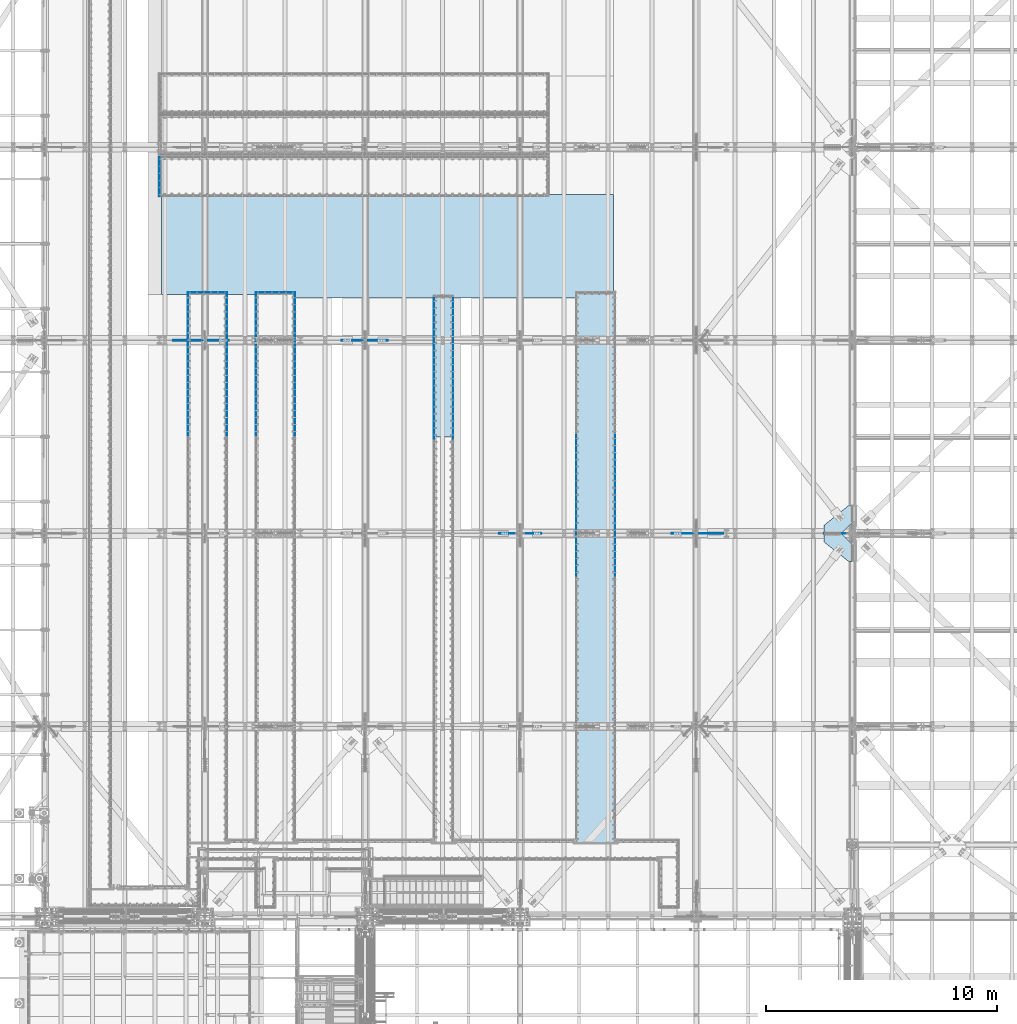
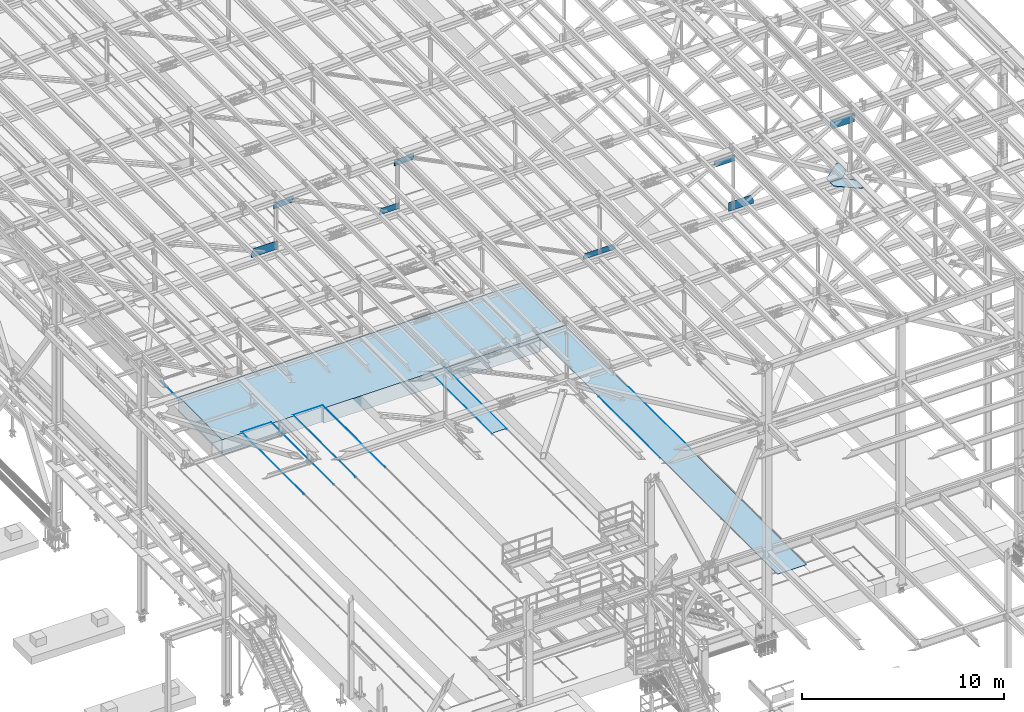
# One storey, part 2981 of 3843: 23 plates, 1 slab, 23 elements without a shape of their own.
"""IFC2X3 building model written with IfcOpenShell, lengths in millimetres."""

from ifc_helpers import new_model, si_unit, frame, origin_with_axes, place, context, subcontext, project, spatial, faceted_brep, material, type_object, element, aggregate, save


model = new_model("IFC2X3")

# Units and contexts
model_context = context("Model", 3, precision=1e-05, world=origin_with_axes())
body_context = subcontext(model_context, "Body", "Model", "MODEL_VIEW")
ifc_project = project(units=[si_unit("LENGTHUNIT", "METRE", prefix="MILLI"), si_unit("AREAUNIT", "SQUARE_METRE"), si_unit("VOLUMEUNIT", "CUBIC_METRE"), si_unit("MASSUNIT", "GRAM", prefix="KILO"), si_unit("TIMEUNIT", "SECOND"), si_unit("PLANEANGLEUNIT", "RADIAN"), si_unit("SOLIDANGLEUNIT", "STERADIAN"), si_unit("THERMODYNAMICTEMPERATUREUNIT", "DEGREE_CELSIUS"), si_unit("LUMINOUSINTENSITYUNIT", "LUMEN")], contexts=[model_context])

# Site, building, storey
site_placement = place(None, origin_with_axes())
site = spatial("IfcSite", under=ifc_project, at=site_placement, CompositionType="ELEMENT")
building_placement = place(site_placement, origin_with_axes())
building = spatial("IfcBuilding", under=site, at=building_placement, Name="Undefined", CompositionType="ELEMENT")
storey_placement = place(building_placement, origin_with_axes())
storey = spatial("IfcBuildingStorey", under=building, at=storey_placement, Name="Undefined", CompositionType="ELEMENT", Elevation=0.0)

# Assembly, plate
assembly_1_placement = place(storey_placement, origin_with_axes())
assembly_1 = element("IfcElementAssembly", 1, at=assembly_1_placement, inside=storey, Name="EMBED_ANGLE", AssemblyPlace="NOTDEFINED", PredefinedType="RIGID_FRAME")
ifc_material_1 = material(Name="STEEL/A36")
plate_type_1 = type_object("IfcPlateType", PredefinedType="NOTDEFINED")
plate_1_placement = place(assembly_1_placement, frame((47028.8619790039, 56784.8750000035, 30480.0000003815), z_axis=(0.0, 1.0, 0.0), x_axis=(0.0, 0.0, -1.0)))
plate_1 = element("IfcPlate", 2, at=plate_1_placement, type_object=plate_type_1, material=ifc_material_1, Name="PLATE", context=body_context, shape_type="Brep", body=[
    faceted_brep([(7.27595761418343e-12, 6.3499999046162, 0.0), (20.6374996185295, 6.35000000000218, -7.27595761418343e-12), (25.399999618523, 1.58750000001601, 4.76249999998981), (25.3999996185303, -6.34999999999854, 12.7000000000044), (0.0, -6.34999999999854, 12.6999998092651), (25.3999996154307, 1.58750000001601, 1697.41850000675), (25.3999996185303, -6.34999999999854, 1689.48100001796), (3.78626282326877e-07, -6.34999999999854, 1689.48100001796), (3.81471181754023e-07, 6.34999999999854, 1702.181), (20.6374996154154, 6.34999999999854, 1702.18100000139)], [[[0, 1, 2, 3, 4]], [[3, 2, 5, 6]], [[4, 3, 6, 7]], [[0, 4, 7, 8]], [[1, 0, 8, 9]], [[2, 1, 9, 5]], [[8, 7, 6, 5, 9]]]),
])
aggregate(assembly_1, [plate_1])

assembly_2_placement = place(storey_placement, origin_with_axes())
assembly_2 = element("IfcElementAssembly", 3, at=assembly_2_placement, inside=storey, Name="EMBED_ANGLE", AssemblyPlace="NOTDEFINED", PredefinedType="RIGID_FRAME")
plate_2_placement = place(assembly_2_placement, frame((51194.4935696441, 52635.1494804688, 30480.0000003815), z_axis=(1.0, 0.0, 0.0), x_axis=(0.0, 0.0, -1.0)))
plate_2 = element("IfcPlate", 4, at=plate_2_placement, type_object=plate_type_1, material=ifc_material_1, Name="PLATE", context=body_context, shape_type="Brep", body=[
    faceted_brep([(3.81471181754023e-07, 6.34999999555293, 1701.76888183631), (3.78611730411649e-07, -6.35000000441505, 1689.00497348848), (25.3999996185303, -6.35000000441505, 1689.00497348848), (25.4000000789456, 1.58749889564206, 1696.9424708618), (20.6375003659959, 6.34999999555293, 1701.76888183631), (25.3999996185303, -6.35000000002765, 12.6775651971911), (25.3999996198218, 1.58727214465034, 4.75431440180546), (20.6374996185295, 6.35000000000218, -7.27595761418343e-12), (7.27595761418343e-12, 6.3499999046162, 0.0), (2.84126144833863e-09, -6.35000000002765, 12.6775651971911)], [[[0, 1, 2, 3, 4]], [[3, 2, 5, 6]], [[4, 3, 6, 7]], [[0, 4, 7, 8]], [[1, 0, 8, 9]], [[2, 1, 9, 5]], [[8, 7, 6, 5, 9]]]),
])
aggregate(assembly_2, [plate_2])

assembly_3_placement = place(storey_placement, origin_with_axes())
assembly_3 = element("IfcElementAssembly", 5, at=assembly_3_placement, inside=storey, Name="EMBED_ANGLE", AssemblyPlace="NOTDEFINED", PredefinedType="RIGID_FRAME")
plate_3_placement = place(assembly_3_placement, frame((48254.4432063764, 52635.1500664063, 30480.0000003815), z_axis=(1.0, 0.0, 0.0), x_axis=(0.0, 0.0, -1.0)))
plate_3 = element("IfcPlate", 6, at=plate_3_placement, type_object=plate_type_1, material=ifc_material_1, Name="PLATE", context=body_context, shape_type="Brep", body=[
    faceted_brep([(3.81471181754023e-07, 6.34999999555293, 1701.76888183631), (3.7862264434807e-07, -6.35000000441505, 1689.0688799162), (25.3999996185303, -6.35000000441505, 1689.0688799162), (25.4000000789638, 1.58749890421313, 1697.00637963295), (20.6375003659959, 6.34999999555293, 1701.76888183631), (25.3999996185303, -6.35000000002037, 12.7000657744793), (25.3999996198218, 1.58727214579267, 4.76283263532969), (20.6374996185295, 6.35000000000218, -7.27595761418343e-12), (7.27595761418343e-12, 6.3499999046162, 0.0), (2.84853740595281e-09, -6.35000000002037, 12.7000657744793)], [[[0, 1, 2, 3, 4]], [[3, 2, 5, 6]], [[4, 3, 6, 7]], [[0, 4, 7, 8]], [[1, 0, 8, 9]], [[2, 1, 9, 5]], [[8, 7, 6, 5, 9]]]),
])
aggregate(assembly_3, [plate_3])

assembly_4_placement = place(storey_placement, origin_with_axes())
assembly_4 = element("IfcElementAssembly", 7, at=assembly_4_placement, inside=storey, Name="EMBED_ANGLE", AssemblyPlace="NOTDEFINED", PredefinedType="RIGID_FRAME")
plate_4_placement = place(assembly_4_placement, frame((66751.962, 46456.6001953125, 30480.0), z_axis=(0.0, -1.0, 0.0), x_axis=(0.0, 0.0, -1.0)))
plate_4 = element("IfcPlate", 8, at=plate_4_placement, type_object=plate_type_1, material=ifc_material_1, Name="PLATE", context=body_context, shape_type="Brep", body=[
    faceted_brep([(25.399999579975, 1.58750000000873, 6096.0000061035), (25.3999996185921, 1.58750000000146, 7.27595761418343e-11), (20.6374996185295, 6.35000000000218, -7.27595761418343e-12), (20.6374984696922, 6.35000000000582, 6096.0), (0.0, -6.3499999046162, 0.0), (3.81471181754023e-07, -6.34999999999854, 6096.0), (3.81471181754023e-07, 6.34999999999854, 6096.0), (7.27595761418343e-12, 6.3499999046162, 0.0), (25.3999996185303, -6.34999999999491, 2.91038304567337e-11), (25.3999996185303, -6.35000000000582, 6096.0)], [[[0, 1, 2, 3]], [[4, 5, 6, 7]], [[8, 9, 5, 4]], [[6, 5, 9, 0, 3]], [[7, 6, 3, 2]], [[8, 4, 7, 2, 1]], [[9, 8, 1, 0]]]),
])
aggregate(assembly_4, [plate_4])

assembly_5_placement = place(storey_placement, origin_with_axes())
assembly_5 = element("IfcElementAssembly", 9, at=assembly_5_placement, inside=storey, Name="EMBED_ANGLE", AssemblyPlace="NOTDEFINED", PredefinedType="RIGID_FRAME")
plate_5_placement = place(assembly_5_placement, frame((65062.9255556641, 46456.6001953125, 30480.0), z_axis=(0.0, -1.0, 0.0), x_axis=(0.0, 0.0, -1.0)))
plate_5 = element("IfcPlate", 10, at=plate_5_placement, type_object=plate_type_1, material=ifc_material_1, Name="PLATE", context=body_context, shape_type="Brep", body=[
    faceted_brep([(25.3999996185521, -1.58750000003783, 6096.0), (20.6375003814719, -6.34999999999854, 6096.00000000139), (20.6375000381231, -6.35000000004948, 2.5465851649642e-11), (25.3999996185921, -1.5874999999869, 7.27595761418343e-11), (0.0, -6.3499999046162, 0.0), (3.81471181754023e-07, -6.34999999999854, 6096.0), (3.81471181754023e-07, 6.34999999999854, 6096.0), (7.27595761418343e-12, 6.3499999046162, 0.0), (25.3999996185303, 6.34999999999854, 6096.00000000171), (25.3999999999942, 6.34999999994034, 2.91038304567337e-11)], [[[0, 1, 2, 3]], [[4, 5, 6, 7]], [[8, 9, 7, 6]], [[9, 8, 0, 3]], [[4, 7, 9, 3, 2]], [[5, 4, 2, 1]], [[8, 6, 5, 1, 0]]]),
])
aggregate(assembly_5, [plate_5])

assembly_6_placement = place(storey_placement, origin_with_axes())
assembly_6 = element("IfcElementAssembly", 11, at=assembly_6_placement, inside=storey, Name="EMBED_ANGLE", AssemblyPlace="NOTDEFINED", PredefinedType="RIGID_FRAME")
plate_6_placement = place(assembly_6_placement, frame((59735.2121692524, 52488.9722657894, 30480.0), z_axis=(0.0, -1.0, 0.0), x_axis=(0.0, 0.0, -1.0)))
plate_6 = element("IfcPlate", 12, at=plate_6_placement, type_object=plate_type_1, material=ifc_material_1, Name="PLATE", context=body_context, shape_type="Brep", body=[
    faceted_brep([(3.81471181754023e-07, 6.34999996374245, 6184.9), (3.81471181754023e-07, -6.35000003625464, 6184.90000000001), (25.3999996185303, -6.35000003625464, 6184.90000000001), (25.4000004415648, 1.58706035211799, 6184.90000016442), (20.6374984696922, 6.34999996374245, 6184.9), (25.3999996185303, -6.34999999999854, 12.7000000000044), (25.3999996191633, 1.58702945142431, 4.76294199092081), (20.6374996185295, 6.35000000000218, -7.27595761418343e-12), (7.27595761418343e-12, 6.3499999046162, 0.0), (0.0, -6.34999999999854, 12.6999998092651)], [[[0, 1, 2, 3, 4]], [[3, 2, 5, 6]], [[4, 3, 6, 7]], [[0, 4, 7, 8]], [[1, 0, 8, 9]], [[2, 1, 9, 5]], [[8, 7, 6, 5, 9]]]),
])
aggregate(assembly_6, [plate_6])

assembly_7_placement = place(storey_placement, origin_with_axes())
assembly_7 = element("IfcElementAssembly", 13, at=assembly_7_placement, inside=storey, Name="EMBED_ANGLE", AssemblyPlace="NOTDEFINED", PredefinedType="RIGID_FRAME")
plate_7_placement = place(assembly_7_placement, frame((58909.8069446428, 52488.9721367188, 30480.0000003815), z_axis=(-5.10699999722418e-06, -0.999999999986959, 0.0), x_axis=(0.0, 0.0, -1.0)))
plate_7 = element("IfcPlate", 14, at=plate_7_placement, type_object=plate_type_1, material=ifc_material_1, Name="PLATE", context=body_context, shape_type="Brep", body=[
    faceted_brep([(25.3999996185303, 6.34999998807325, 6184.89987113706), (3.81471181754023e-07, 6.34999998807325, 6184.89987113706), (3.81471181754023e-07, -6.35000001190929, 6184.89987113703), (20.637498469714, -6.35000001190929, 6184.89987113703), (25.3999996185521, -1.58750068734662, 6184.89987113704), (25.3999996185303, 6.34999999996217, 12.731334147873), (7.8580342233181e-10, 6.34999999996217, 12.731334147873), (0.0, -6.3499999046162, 0.0), (20.6375000381231, -6.35000000004948, 2.5465851649642e-11), (25.3999996185303, -1.61906264965364, 4.76235011019162)], [[[0, 1, 2, 3, 4]], [[1, 0, 5, 6]], [[2, 1, 6, 7]], [[3, 2, 7, 8]], [[4, 3, 8, 9]], [[0, 4, 9, 5]], [[8, 7, 6, 5, 9]]]),
])
aggregate(assembly_7, [plate_7])

assembly_8_placement = place(storey_placement, origin_with_axes())
assembly_8 = element("IfcElementAssembly", 15, at=assembly_8_placement, inside=storey, Name="EMBED_ANGLE", AssemblyPlace="NOTDEFINED", PredefinedType="RIGID_FRAME")
plate_8_placement = place(assembly_8_placement, frame((52889.9124531822, 52641.4990243902, 30480.0), z_axis=(-1.03329999983543e-05, -0.999999999946615, 0.0), x_axis=(0.0, 0.0, -1.0)))
plate_8 = element("IfcPlate", 16, at=plate_8_placement, type_object=plate_type_1, material=ifc_material_1, Name="PLATE", context=body_context, shape_type="Brep", body=[
    faceted_brep([(7.27595761418343e-12, 6.34999998678541, 6184.89941540622), (7.27595761418343e-12, -6.35000001324806, 6184.89941540619), (25.3999992370664, -6.35000001324806, 6184.89941540619), (25.4000004415793, 1.58705640731932, 6184.89941540621), (20.6374992927413, 6.34999998678541, 6184.89941540622), (25.3999996177517, -6.3500000000422, 12.6362810351784), (25.3999996191633, 1.52319705695845, 4.76292397471843), (20.6374996185295, 6.35000000000218, -7.27595761418343e-12), (7.27595761418343e-12, 6.3499999046162, 0.0), (0.0, -6.3500000000422, 12.6362810351857)], [[[0, 1, 2, 3, 4]], [[3, 2, 5, 6]], [[4, 3, 6, 7]], [[0, 4, 7, 8]], [[1, 0, 8, 9]], [[2, 1, 9, 5]], [[8, 7, 6, 5, 9]]]),
])
aggregate(assembly_8, [plate_8])

assembly_9_placement = place(storey_placement, origin_with_axes())
assembly_9 = element("IfcElementAssembly", 17, at=assembly_9_placement, inside=storey, Name="EMBED_ANGLE", AssemblyPlace="NOTDEFINED", PredefinedType="RIGID_FRAME")
plate_9_placement = place(assembly_9_placement, frame((51200.8435713459, 52641.4994804688, 30480.0000003815), z_axis=(-5.10699999722418e-06, -0.999999999986959, 0.0), x_axis=(0.0, 0.0, -1.0)))
plate_9 = element("IfcPlate", 18, at=plate_9_placement, type_object=plate_type_1, material=ifc_material_1, Name="PLATE", context=body_context, shape_type="Brep", body=[
    faceted_brep([(25.3999996185303, 6.34999998807325, 6184.89987113706), (3.81471181754023e-07, 6.34999998807325, 6184.89987113706), (3.81471181754023e-07, -6.35000001190929, 6184.89987113703), (20.637498469714, -6.35000001190929, 6184.89987113703), (25.3999996185521, -1.58750068734662, 6184.89987113704), (25.3999996185303, 6.34999999996217, 12.7229855896076), (7.8580342233181e-10, 6.34999999996217, 12.7229855896076), (0.0, -6.3499999046162, 0.0), (20.6375000381231, -6.35000000004948, 2.5465851649642e-11), (25.3999996185303, -1.61906276626542, 4.73951990913338)], [[[0, 1, 2, 3, 4]], [[1, 0, 5, 6]], [[2, 1, 6, 7]], [[3, 2, 7, 8]], [[4, 3, 8, 9]], [[0, 4, 9, 5]], [[8, 7, 6, 5, 9]]]),
])
aggregate(assembly_9, [plate_9])

assembly_10_placement = place(storey_placement, origin_with_axes())
assembly_10 = element("IfcElementAssembly", 19, at=assembly_10_placement, inside=storey, Name="EMBED_ANGLE", AssemblyPlace="NOTDEFINED", PredefinedType="RIGID_FRAME")
plate_10_placement = place(assembly_10_placement, frame((49949.8620881851, 52641.4996228586, 30480.0000003815), z_axis=(0.0, -1.0, 0.0), x_axis=(0.0, 0.0, -1.0)))
plate_10 = element("IfcPlate", 20, at=plate_10_placement, type_object=plate_type_1, material=ifc_material_1, Name="PLATE", context=body_context, shape_type="Brep", body=[
    faceted_brep([(3.81471181754023e-07, 6.34999996374245, 6184.9), (3.81471181754023e-07, -6.35000003625464, 6184.90000000001), (25.3999996185303, -6.35000003625464, 6184.90000000001), (25.4000004415648, 1.58706035211799, 6184.90000016442), (20.6374984696922, 6.34999996374245, 6184.9), (25.3999996185303, -6.34999999999854, 12.7000000000044), (25.3999996191633, 1.58702945142431, 4.76294199092081), (20.6374996185295, 6.35000000000218, -7.27595761418343e-12), (7.27595761418343e-12, 6.3499999046162, 0.0), (0.0, -6.34999999999854, 12.6999998092651)], [[[0, 1, 2, 3, 4]], [[3, 2, 5, 6]], [[4, 3, 6, 7]], [[0, 4, 7, 8]], [[1, 0, 8, 9]], [[2, 1, 9, 5]], [[8, 7, 6, 5, 9]]]),
])
aggregate(assembly_10, [plate_10])

assembly_11_placement = place(storey_placement, origin_with_axes())
assembly_11 = element("IfcElementAssembly", 21, at=assembly_11_placement, inside=storey, Name="EMBED_ANGLE", AssemblyPlace="NOTDEFINED", PredefinedType="RIGID_FRAME")
plate_11_placement = place(assembly_11_placement, frame((48260.7932073747, 52641.5000791333, 30480.0000003815), z_axis=(-5.10699999722418e-06, -0.999999999986959, 0.0), x_axis=(0.0, 0.0, -1.0)))
plate_11 = element("IfcPlate", 22, at=plate_11_placement, type_object=plate_type_1, material=ifc_material_1, Name="PLATE", context=body_context, shape_type="Brep", body=[
    faceted_brep([(25.3999996185303, 6.34999998807325, 6184.89987113706), (3.81471181754023e-07, 6.34999998807325, 6184.89987113706), (3.81471181754023e-07, -6.35000001190929, 6184.89987113703), (20.637498469714, -6.35000001190929, 6184.89987113703), (25.3999996185521, -1.58750068734662, 6184.89987113704), (25.3999996185303, 6.34999999997672, 12.699855768049), (6.22832885710523e-06, 6.35000000002037, 12.6998528713375), (0.0, -6.3499999046162, 0.0), (20.6375000381231, -6.35000000004948, 2.5465851649642e-11), (25.3999996185303, -1.6190621206697, 4.7308316089111)], [[[0, 1, 2, 3, 4]], [[1, 0, 5, 6]], [[2, 1, 6, 7]], [[3, 2, 7, 8]], [[4, 3, 8, 9]], [[0, 4, 9, 5]], [[8, 7, 6, 5, 9]]]),
])
aggregate(assembly_11, [plate_11])

assembly_12_placement = place(storey_placement, origin_with_axes())
assembly_12 = element("IfcElementAssembly", 23, at=assembly_12_placement, inside=storey, Name="PLATE", AssemblyPlace="NOTDEFINED", PredefinedType="RIGID_FRAME")
ifc_material_2 = material(Name="STEEL/A572-50")
plate_type_2 = type_object("IfcPlateType", PredefinedType="NOTDEFINED")
plate_12_placement = place(assembly_12_placement, frame((58922.4754681141, 46373.9221406259, 30467.3), z_axis=(0.0, 1.0, 0.0), x_axis=(1.0, 0.0, 0.0)))
plate_12 = element("IfcPlate", 24, at=plate_12_placement, type_object=plate_type_2, material=ifc_material_2, Name="PLATE", context=body_context, shape_type="Brep", body=[
    faceted_brep([(0.0, -12.6999999999971, 0.0), (-0.00374851834203582, -12.7000000000007, 6095.99999999916), (-0.00374851834203582, 12.7000000000007, 6095.99999999916), (0.0, 12.6999999999971, 0.0), (800.03667504531, -12.7000000000007, 6096.00000000056), (800.03667504531, 12.7000000000007, 6096.00000000056), (800.036639650629, -12.7000000000007, 5.49334799870849e-10), (800.036639650629, 12.7000000000007, 5.49334799870849e-10)], [[[0, 1, 2, 3]], [[1, 4, 5, 2]], [[4, 6, 7, 5]], [[6, 0, 3, 7]], [[5, 7, 3, 2]], [[6, 4, 1, 0]]]),
])
aggregate(assembly_12, [plate_12])

assembly_13_placement = place(storey_placement, origin_with_axes())
assembly_13 = element("IfcElementAssembly", 25, at=assembly_13_placement, inside=storey, Name="TRENCH COVER", AssemblyPlace="NOTDEFINED", PredefinedType="RIGID_FRAME")
ifc_material_3 = material(Name="STEEL/Steel_Undefined")
plate_type_3 = type_object("IfcPlateType", PredefinedType="NOTDEFINED")
plate_13_placement = place(assembly_13_placement, frame((65081.912, 28809.95, 30467.3), z_axis=(0.0, 1.0, 0.0), x_axis=(1.0, 0.0, 0.0)))
plate_13 = element("IfcPlate", 26, at=plate_13_placement, type_object=plate_type_3, material=ifc_material_3, Name="TRENCH COVER", context=body_context, shape_type="Brep", body=[
    faceted_brep([(0.0, -12.6999999999971, 0.0), (0.00638351428642636, -12.7000000000007, 23806.1500596228), (0.00638351428642636, 12.7000000000007, 23806.1500596228), (0.0, 12.6999999999971, 0.0), (1651.00000084208, -12.7000000000007, 23806.1500595694), (1651.00000084208, 12.7000000000007, 23806.1500595694), (1651.0, -12.7000000000007, 0.0), (1651.0, 12.7000000000007, 0.0)], [[[0, 1, 2, 3]], [[1, 4, 5, 2]], [[4, 6, 7, 5]], [[6, 0, 3, 7]], [[5, 7, 3, 2]], [[6, 4, 1, 0]]]),
])
aggregate(assembly_13, [plate_13])

assembly_14_placement = place(storey_placement, origin_with_axes())
assembly_14 = element("IfcElementAssembly", 27, at=assembly_14_placement, inside=storey, Name="PLATE", AssemblyPlace="NOTDEFINED", PredefinedType="RIGID_FRAME")
plate_type_4 = type_object("IfcPlateType", PredefinedType="NOTDEFINED")
plate_14_placement = place(assembly_14_placement, frame((77008.037497805, 42684.7000000023, 42232.2625000009), z_axis=(-1.0, 0.0, 0.0), x_axis=(0.0, 1.0, 0.0)))
plate_14 = element("IfcPlate", 28, at=plate_14_placement, type_object=plate_type_4, material=ifc_material_2, Name="PLATE", context=body_context, shape_type="Brep", body=[
    faceted_brep([(0.0, -14.2874999999985, 0.0), (-475.456250002258, -14.2874999999985, 477.837502193986), (-475.456250002258, 14.2874999999985, 477.837502193986), (0.0, 14.2874999999985, 0.0), (-475.456250002258, -14.2874999999985, 1214.4375021945), (-475.456250002258, 14.2874999999985, 1214.4375021945), (-125.919147861619, -14.2874999999985, 1214.43750308026), (-125.919147861619, 14.2874999999985, 1214.43750308026), (736.600000090519, -14.2874999999985, 147.637499993114), (736.600000090519, 14.2874999999985, 147.637499993114), (736.599999940488, -14.2874999999985, 0.0), (736.599999940488, 14.2874999999985, 0.0)], [[[0, 1, 2, 3]], [[1, 4, 5, 2]], [[4, 6, 7, 5]], [[6, 8, 9, 7]], [[8, 10, 11, 9]], [[10, 0, 3, 11]], [[5, 7, 9, 11, 3, 2]], [[10, 8, 6, 4, 1, 0]]]),
])
aggregate(assembly_14, [plate_14])

assembly_15_placement = place(storey_placement, origin_with_axes())
assembly_15 = element("IfcElementAssembly", 29, at=assembly_15_placement, inside=storey, Name="PLATE", AssemblyPlace="NOTDEFINED", PredefinedType="RIGID_FRAME")
plate_15_placement = place(assembly_15_placement, frame((77006.4499999999, 41719.4999999977, 42232.2625000009), z_axis=(-1.0, 0.0, 0.0), x_axis=(0.0, -1.0, 0.0)))
plate_15 = element("IfcPlate", 30, at=plate_15_placement, type_object=plate_type_4, material=ifc_material_2, Name="PLATE", context=body_context, shape_type="Brep", body=[
    faceted_brep([(0.0, -14.2874999999985, 0.0), (-475.45624995463, -14.2874999999985, 476.25000003165), (-475.45624995463, 14.2874999999985, 476.25000003165), (0.0, 14.2874999999985, 0.0), (-475.45624994392, -14.2874999999985, 1212.85000003893), (-475.45624994392, 14.2874999999985, 1212.85000003893), (-101.97154243727, -14.2874999999985, 1212.84999999934), (-101.97154243727, 14.2874999999985, 1212.84999999934), (736.600000090519, -14.2874999999985, 147.637499993114), (736.600000090519, 14.2874999999985, 147.637499993114), (736.599999940488, -14.2874999999985, 0.0), (736.599999940488, 14.2874999999985, 0.0)], [[[0, 1, 2, 3]], [[1, 4, 5, 2]], [[4, 6, 7, 5]], [[6, 8, 9, 7]], [[8, 10, 11, 9]], [[10, 0, 3, 11]], [[5, 7, 9, 11, 3, 2]], [[10, 8, 6, 4, 1, 0]]]),
])
aggregate(assembly_15, [plate_15])

assembly_16_placement = place(storey_placement, origin_with_axes())
assembly_16 = element("IfcElementAssembly", 31, at=assembly_16_placement, inside=storey, Name="BEAM", AssemblyPlace="NOTDEFINED", PredefinedType="RIGID_FRAME")
plate_type_5 = type_object("IfcPlateType", PredefinedType="NOTDEFINED")
plate_16_placement = place(assembly_16_placement, frame((71422.2526348031, 42202.1, 42510.1105084375), z_axis=(0.000471589999913703, 0.0, 0.99999988880143), x_axis=(-0.99999988880143, 0.0, 0.000471589999906888)))
plate_16 = element("IfcPlate", 32, at=plate_16_placement, type_object=plate_type_5, material=ifc_material_2, Name="PLATE", context=body_context, shape_type="Brep", body=[
    faceted_brep([(0.0, -9.52500000000146, 0.0), (1.01863406598568e-10, -9.52500000000146, 272.090448276002), (1.01863406598568e-10, 9.52500000000146, 272.090448276002), (0.0, 9.52500000000146, 0.0), (150.239723151113, -9.52500000000146, 537.290499099865), (150.239723151113, 9.52500000000146, 537.290499099865), (1407.40589564678, -9.52500000000146, 537.290499099377), (1407.40589564678, 9.52500000000146, 537.290499099377), (1407.40589564657, -9.52500000000146, -5.67524693906307e-10), (1407.40589564657, 9.52500000000146, -5.67524693906307e-10)], [[[0, 1, 2, 3]], [[1, 4, 5, 2]], [[4, 6, 7, 5]], [[6, 8, 9, 7]], [[8, 0, 3, 9]], [[5, 7, 9, 3, 2]], [[8, 6, 4, 1, 0]]]),
])
aggregate(assembly_16, [plate_16])

assembly_17_placement = place(storey_placement, origin_with_axes())
assembly_17 = element("IfcElementAssembly", 33, at=assembly_17_placement, inside=storey, Name="BEAM", AssemblyPlace="NOTDEFINED", PredefinedType="RIGID_FRAME")
plate_type_6 = type_object("IfcPlateType", PredefinedType="NOTDEFINED")
plate_17_placement = place(assembly_17_placement, frame((70370.2799363057, 42202.1, 45819.46058084), z_axis=(0.020751511004375, 0.0, -0.999784664210767), x_axis=(-0.999784664210767, 0.0, -0.020751511004377)))
plate_17 = element("IfcPlate", 34, at=plate_17_placement, type_object=plate_type_6, material=ifc_material_2, Name="PLATE", context=body_context, shape_type="Brep", body=[
    faceted_brep([(0.0, -9.52500000000146, 0.0), (7.45481308027229, -9.52500000000146, 379.376743905574), (7.45481308027229, 9.52500000000146, 379.376743905574), (0.0, 9.52500000000146, 0.0), (1074.34431757565, -9.52500000000146, 357.230652593513), (1074.34431757565, 9.52500000000146, 357.230652593513), (1180.24893568821, -9.52500000000146, 126.362263331132), (1180.24893568821, 9.52500000000146, 126.362263331132), (1180.24893568968, -9.52500000000146, 5.20230969414115e-09), (1180.24893568968, 9.52500000000146, 5.20230969414115e-09)], [[[0, 1, 2, 3]], [[1, 4, 5, 2]], [[4, 6, 7, 5]], [[6, 8, 9, 7]], [[8, 0, 3, 9]], [[5, 7, 9, 3, 2]], [[8, 6, 4, 1, 0]]]),
])

assembly_18_placement = place(storey_placement, origin_with_axes())
assembly_18 = element("IfcElementAssembly", 35, at=assembly_18_placement, inside=storey, Name="BEAM", AssemblyPlace="NOTDEFINED", PredefinedType="RIGID_FRAME")
plate_type_7 = type_object("IfcPlateType", PredefinedType="NOTDEFINED")
plate_18_placement = place(assembly_18_placement, frame((50019.7354820449, 50558.7, 45373.8203628462), z_axis=(0.024894295999773, 0.0, -0.999690088990921), x_axis=(-0.999690088990921, 0.0, -0.0248942959997753)))
plate_18 = element("IfcPlate", 36, at=plate_18_placement, type_object=plate_type_7, material=ifc_material_2, Name="PLATE", context=body_context, shape_type="Brep", body=[
    faceted_brep([(0.0, -9.52500000000146, 0.0), (-3.78349795937538e-10, -9.52500000000146, 136.608574617123), (-3.78349795937538e-10, 9.52500000000146, 136.608574617123), (0.0, 9.52500000000146, 0.0), (112.580575755448, -9.52500000000146, 364.296110451236), (112.580575755448, 9.52500000000146, 364.296110451236), (1146.83237623273, -9.52500000000146, 364.296110454045), (1146.83237623273, 9.52500000000146, 364.296110454045), (1138.14882315512, -9.52500000000146, 3.09955794364214e-09), (1138.14882315512, 9.52500000000146, 3.09955794364214e-09)], [[[0, 1, 2, 3]], [[1, 4, 5, 2]], [[4, 6, 7, 5]], [[6, 8, 9, 7]], [[8, 0, 3, 9]], [[5, 7, 9, 3, 2]], [[8, 6, 4, 1, 0]]]),
])
aggregate(assembly_18, [plate_18])

# Plate
plate_type_8 = type_object("IfcPlateType", PredefinedType="NOTDEFINED")
plate_19_placement = place(assembly_17_placement, frame((77196.9499980926, 42202.1, 45956.7414766317), z_axis=(0.0195980529944354, 0.0, -0.999807939715837), x_axis=(-0.999807939715837, 0.0, -0.019598052994431)))
plate_19 = element("IfcPlate", 37, at=plate_19_placement, type_object=plate_type_8, material=ifc_material_2, Name="PLATE", context=body_context, shape_type="Brep", body=[
    faceted_brep([(0.0, -9.52500000000146, 0.0), (10.8364776045346, -9.52500000000146, 552.830258495094), (10.8364776045346, 9.52500000000146, 552.830258495094), (0.0, 9.52500000000146, 0.0), (1255.61910090379, -9.52500000000146, 528.430257205662), (1255.61910090379, 9.52500000000146, 528.430257205662), (1400.50611778346, -9.52500000000146, 260.268377529654), (1400.50611778346, 9.52500000000146, 260.268377529654), (1400.50611778408, -9.52500000000146, 3.7325662560761e-09), (1400.50611778408, 9.52500000000146, 3.7325662560761e-09)], [[[0, 1, 2, 3]], [[1, 4, 5, 2]], [[4, 6, 7, 5]], [[6, 8, 9, 7]], [[8, 0, 3, 9]], [[5, 7, 9, 3, 2]], [[8, 6, 4, 1, 0]]]),
])

aggregate(assembly_17, [plate_19, plate_17])

# Assembly, plate
assembly_19_placement = place(storey_placement, origin_with_axes())
assembly_19 = element("IfcElementAssembly", 38, at=assembly_19_placement, inside=storey, Name="BEAM", AssemblyPlace="NOTDEFINED", PredefinedType="RIGID_FRAME")
plate_type_9 = type_object("IfcPlateType", PredefinedType="NOTDEFINED")
plate_20_placement = place(assembly_19_placement, frame((56893.7620579448, 50558.7, 45538.6793985032), z_axis=(0.0235736219896208, 0.0, -0.99972210355993), x_axis=(-0.99972210355993, 0.0, -0.0235736219896237)))
plate_20 = element("IfcPlate", 39, at=plate_20_placement, type_object=plate_type_9, material=ifc_material_2, Name="PLATE", context=body_context, shape_type="Brep", body=[
    faceted_brep([(0.0, -9.52500000000146, 0.0), (-2.25554686039686e-10, -9.52500000000146, 154.985962991494), (-2.25554686039686e-10, 9.52500000000146, 154.985962991494), (0.0, 9.52500000000146, 0.0), (107.499340591574, -9.52500000000146, 356.732964943898), (107.499340591574, 9.52500000000146, 356.732964943898), (1130.4356911705, -9.52500000000146, 356.732964945411), (1130.4356911705, 9.52500000000146, 356.732964945411), (1122.02386537444, -9.52500000000146, 1.64436642080545e-09), (1122.02386537444, 9.52500000000146, 1.64436642080545e-09)], [[[0, 1, 2, 3]], [[1, 4, 5, 2]], [[4, 6, 7, 5]], [[6, 8, 9, 7]], [[8, 0, 3, 9]], [[5, 7, 9, 3, 2]], [[8, 6, 4, 1, 0]]]),
])
aggregate(assembly_19, [plate_20])

assembly_20_placement = place(storey_placement, origin_with_axes())
assembly_20 = element("IfcElementAssembly", 40, at=assembly_20_placement, inside=storey, Name="BEAM", AssemblyPlace="NOTDEFINED", PredefinedType="RIGID_FRAME")
plate_21_placement = place(assembly_20_placement, frame((56045.9842914489, 50558.7, 42513.1617157366), z_axis=(-0.00249371299923223, 0.0, 0.999996890692905), x_axis=(-0.999996890692905, 0.0, -0.0024937129992316)))
plate_21 = element("IfcPlate", 41, at=plate_21_placement, type_object=plate_type_9, material=ifc_material_2, Name="PLATE", context=body_context, shape_type="Brep", body=[
    faceted_brep([(0.0, -9.52500000000146, 0.0), (3.27418092638254e-10, -9.52500000000146, 354.60831139778), (3.27418092638254e-10, 9.52500000000146, 354.60831139778), (0.0, 9.52500000000146, 0.0), (1034.26641666368, -9.52500000000146, 357.187483295624), (1034.26641666368, 9.52500000000146, 357.187483295624), (1141.71824970358, -9.52500000000146, 127.03513464937), (1141.71824970358, 9.52500000000146, 127.03513464937), (1141.71824970346, -9.52500000000146, -1.03318598121405e-09), (1141.71824970346, 9.52500000000146, -1.03318598121405e-09)], [[[0, 1, 2, 3]], [[1, 4, 5, 2]], [[4, 6, 7, 5]], [[6, 8, 9, 7]], [[8, 0, 3, 9]], [[5, 7, 9, 3, 2]], [[8, 6, 4, 1, 0]]]),
])
aggregate(assembly_20, [plate_21])

assembly_21_placement = place(storey_placement, origin_with_axes())
assembly_21 = element("IfcElementAssembly", 42, at=assembly_21_placement, inside=storey, Name="BEAM", AssemblyPlace="NOTDEFINED", PredefinedType="RIGID_FRAME")
plate_type_10 = type_object("IfcPlateType", PredefinedType="NOTDEFINED")
plate_22_placement = place(assembly_21_placement, frame((63552.1217968801, 42202.1, 42509.9843623108), z_axis=(-0.000880944999975329, 0.0, 0.999999611967878), x_axis=(-0.999999611967878, 0.0, -0.000880944999972497)))
plate_22 = element("IfcPlate", 43, at=plate_22_placement, type_object=plate_type_10, material=ifc_material_2, Name="PLATE", context=body_context, shape_type="Brep", body=[
    faceted_brep([(0.0, -9.52500000000146, 0.0), (1.52795109897852e-10, -9.52500000000146, 145.742600514364), (1.52795109897852e-10, 9.52500000000146, 145.742600514364), (0.0, 9.52500000000146, 0.0), (89.079037880445, -9.52500000000146, 330.169765970786), (89.079037880445, 9.52500000000146, 330.169765970786), (1737.40018770193, -9.52500000000146, 330.169765969149), (1737.40018770193, 9.52500000000146, 330.169765969149), (1817.47742943747, -9.52500000000146, 171.423185495041), (1817.47742943747, 9.52500000000146, 171.423185495041), (1817.4774294373, -9.52500000000146, -1.80443748831749e-09), (1817.4774294373, 9.52500000000146, -1.80443748831749e-09)], [[[0, 1, 2, 3]], [[1, 4, 5, 2]], [[4, 6, 7, 5]], [[6, 8, 9, 7]], [[8, 10, 11, 9]], [[10, 0, 3, 11]], [[5, 7, 9, 11, 3, 2]], [[10, 8, 6, 4, 1, 0]]]),
])
aggregate(assembly_21, [plate_22])

assembly_22_placement = place(storey_placement, origin_with_axes())
assembly_22 = element("IfcElementAssembly", 44, at=assembly_22_placement, inside=storey, Name="BEAM", AssemblyPlace="NOTDEFINED", PredefinedType="RIGID_FRAME")
plate_type_11 = type_object("IfcPlateType", PredefinedType="NOTDEFINED")
plate_23_placement = place(assembly_22_placement, frame((49112.8347522252, 50558.7, 42492.0286674662), z_axis=(-0.00382132899883437, 0.0, 0.999992698695687), x_axis=(-0.999992698695687, 0.0, -0.0038213289988363)))
plate_23 = element("IfcPlate", 45, at=plate_23_placement, type_object=plate_type_11, material=ifc_material_2, Name="PLATE", context=body_context, shape_type="Brep", body=[
    faceted_brep([(0.0, -9.52500000000146, 0.0), (1.02591002359986e-09, -9.52500000000146, 508.341783045842), (1.02591002359986e-09, 9.52500000000146, 508.341783045842), (0.0, 9.52500000000146, 0.0), (1369.2113937645, -9.52500000000146, 513.574458853313), (1369.2113937645, 9.52500000000146, 513.574458853313), (1493.34419643319, -9.52500000000146, 235.196860302072), (1493.34419643319, 9.52500000000146, 235.196860302072), (1493.34419643272, -9.52500000000146, -3.01224645227194e-09), (1493.34419643272, 9.52500000000146, -3.01224645227194e-09)], [[[0, 1, 2, 3]], [[1, 4, 5, 2]], [[4, 6, 7, 5]], [[6, 8, 9, 7]], [[8, 0, 3, 9]], [[5, 7, 9, 3, 2]], [[8, 6, 4, 1, 0]]]),
])
aggregate(assembly_22, [plate_23])

# Assembly, slab
assembly_23_placement = place(storey_placement, origin_with_axes())
assembly_23 = element("IfcElementAssembly", 46, at=assembly_23_placement, inside=storey, Name="SLAB", AssemblyPlace="NOTDEFINED", PredefinedType="REINFORCEMENT_UNIT")
ifc_material_4 = material(Name="CONCRETE/3000")
slab_type = type_object("IfcSlabType", PredefinedType="NOTDEFINED")
slab_placement = place(assembly_23_placement, frame((47111.4119790039, 56873.775, 30022.8), z_axis=(1.0, 0.0, 0.0), x_axis=(0.0, -1.0, 0.0)))
slab = element("IfcSlab", 47, at=slab_placement, type_object=slab_type, material=ifc_material_4, Name="SLAB", PredefinedType="FLOOR", context=body_context, shape_type="Brep", body=[
    faceted_brep([(76.2001952999708, -431.800002514607, -0.000824091614049394), (76.2002031003867, -431.800002511613, 16751.2991977511), (7.7877557487227e-06, -431.799999996998, 16751.2991977866), (0.0, -431.800000000287, 0.0), (76.2002022622764, -457.20000333765, 16751.2991977511), (76.2001944618605, -457.200000000001, 0.0), (0.0, -457.200000000001, 16751.2991977866), (4473.70273424812, -431.800013385418, 12617.4501606352), (4397.50283173995, -431.800013766308, 12617.4501606351), (4397.50286132832, -431.800000762658, 11804.7133696031), (4473.70273437306, -431.800000381765, 11804.7133813382), (4473.70273437508, -457.199987044951, 12617.4501602288), (4397.50283186691, -457.19999351423, 12617.4501602287), (4397.50286145529, -457.199993454953, 11804.7133691967), (4473.70298389802, -457.199985101084, 11804.7133809318), (4321.3017578125, 457.200000000001, 18034.0), (4321.3017578125, 457.200000000001, 19558.0), (4321.3017578125, -431.800000305193, 19558.0), (4321.3017578125, -431.800000304953, 18034.0), (4473.70263671875, 457.200000000001, 18034.0), (4473.70263670966, -431.800000000014, 18034.0635766602), (4473.70263671875, 457.200000000001, 5695.9501953125), (4321.1748046875, 457.200000000001, 5695.9501953125), (4321.1748046875, 457.200000000001, 0.0), (0.0, 457.200000000001, 0.0), (0.0, 457.200000000001, 19558.0), (0.0, -457.200000000001, 19558.0), (4244.97536585427, -457.200000000001, 19558.0), (4244.97536580345, -431.800000457675, 19558.0), (4244.97493703056, -457.199993500868, 17957.9272146199), (4244.97493697974, -431.800000457675, 17957.9272146199), (4473.70263809028, -457.199999818051, 17957.9271533203), (4473.70273436591, -431.800000000014, 17957.9271533203), (4473.70332011675, -457.199970672533, 5772.08683243598), (4473.70331973568, -431.799970672535, 5772.08683205491), (4473.70263671875, -431.799971815501, 5695.9501953125), (4321.1748046875, -431.799974103324, 5695.9501953125), (4244.97665862662, -431.799974103295, 5772.0868320832), (4244.97552291692, -431.799999248287, 4095.6863874824), (4321.1757811645, -431.799998105333, 4095.68636705108), (4244.97665900769, -457.199974103292, 5772.08683246427), (4244.97552329799, -457.199999248289, 4095.68638786348), (4321.1748046875, -457.200000000001, 4095.68636743215), (4244.97493710817, -457.199991983874, 1155.67372561744), (4244.97493698121, -431.800000762931, 1155.67372561744), (4244.84902235764, -431.800000763564, 2832.1000786079), (4244.8490224846, -457.199992106358, 2832.1000786079), (4321.1748046875, -457.200000000001, 1155.67370519567), (4321.17480468684, -431.800000382038, 1155.67370519567), (4321.17539049804, -431.800000382038, 2832.10007860792), (4321.17539062501, -457.199999999997, 2832.10007860792), (4321.1748046875, -457.200000000001, 0.0)], [[[0, 1, 2, 3]], [[4, 1, 0, 5]], [[6, 2, 1, 4]], [[7, 8, 9, 10]], [[11, 12, 8, 7]], [[13, 9, 8, 12]], [[14, 10, 9, 13]], [[15, 16, 17, 18]], [[19, 15, 18, 20]], [[16, 15, 19, 21, 22, 23, 24, 25]], [[16, 25, 26, 27, 28, 17]], [[27, 29, 30, 28]], [[31, 32, 30, 29]], [[20, 18, 17, 28, 30, 32]], [[31, 11, 7, 10, 14, 33, 34, 35, 21, 19, 20, 32]], [[22, 21, 35, 36]], [[34, 37, 38, 39, 36, 35]], [[33, 40, 37, 34]], [[41, 38, 37, 40]], [[42, 39, 38, 41]], [[43, 44, 45, 46]], [[47, 48, 44, 43]], [[49, 45, 44, 48]], [[50, 46, 45, 49]], [[48, 47, 51, 23, 22, 36, 39, 42, 50, 49]], [[3, 24, 23, 51, 5, 0]], [[26, 25, 24, 3, 2, 6]], [[51, 47, 43, 46, 50, 42, 41, 40, 33, 14, 13, 12, 11, 31, 29, 27, 26, 6, 4, 5]]]),
])
aggregate(assembly_23, [slab])

save(model, "model.ifc")
